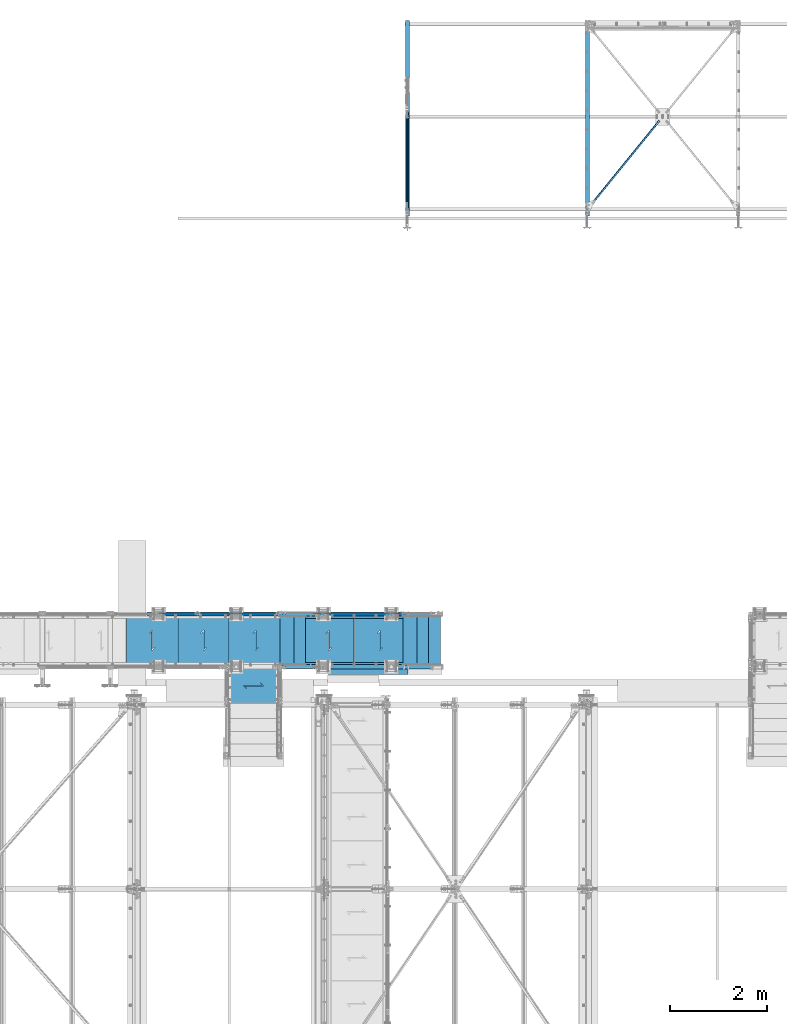
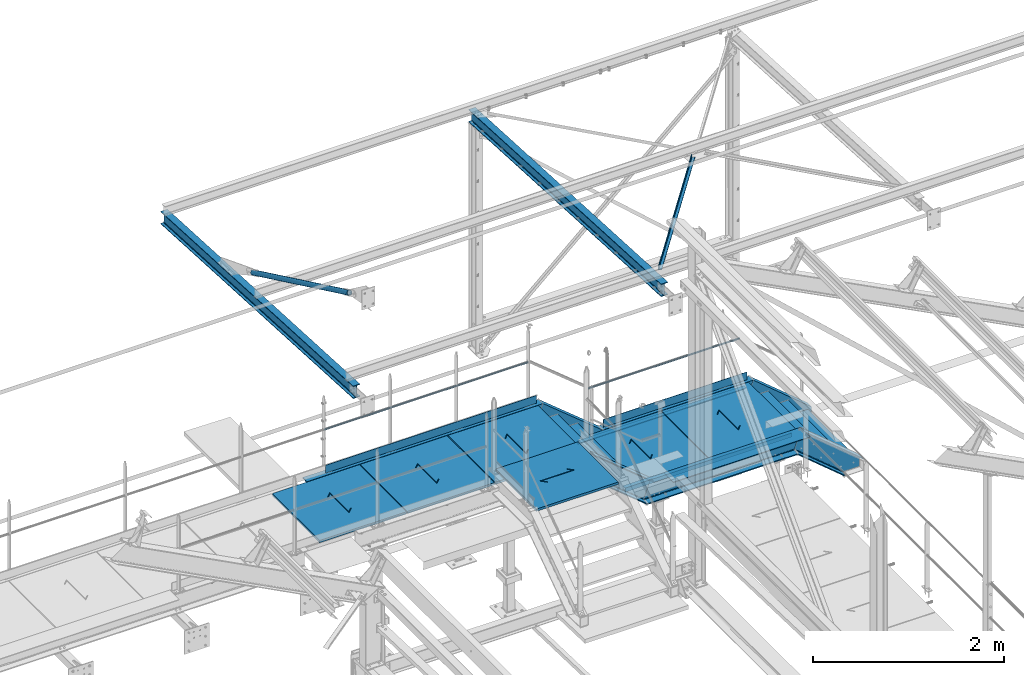
# One storey, part 53 of 496: 24 beams, 5 members, 21 elements without a shape of their own.
"""IFC2X3 building model written with IfcOpenShell, lengths in millimetres."""

from ifc_helpers import new_model, si_unit, frame, frame_2d, origin_with_axes, origin_2d_with_axis, place, context, subcontext, project, spatial, polyline, circle_curve, parameter, trimmed, segment, composite_curve, rectangle, hollow_circle, i_section, l_section, u_section, outline, extrude, boolean, clip, halfspace, material, type_object, element, aggregate, save


model = new_model("IFC2X3")

# Units and contexts
model_context = context("Model", 3, precision=1e-05, world=origin_with_axes())
body_context = subcontext(model_context, "Body", "Model", "MODEL_VIEW")
ifc_project = project(units=[si_unit("LENGTHUNIT", "METRE", prefix="MILLI"), si_unit("AREAUNIT", "SQUARE_METRE"), si_unit("VOLUMEUNIT", "CUBIC_METRE"), si_unit("MASSUNIT", "GRAM", prefix="KILO"), si_unit("TIMEUNIT", "SECOND"), si_unit("PLANEANGLEUNIT", "RADIAN"), si_unit("SOLIDANGLEUNIT", "STERADIAN"), si_unit("THERMODYNAMICTEMPERATUREUNIT", "DEGREE_CELSIUS"), si_unit("LUMINOUSINTENSITYUNIT", "LUMEN")], contexts=[model_context])

# Site, building, storey
site_placement = place(None, origin_with_axes())
site = spatial("IfcSite", under=ifc_project, at=site_placement, CompositionType="ELEMENT")
building_placement = place(site_placement, origin_with_axes())
building = spatial("IfcBuilding", under=site, at=building_placement, Name="Undefined", CompositionType="ELEMENT")
storey_placement = place(building_placement, origin_with_axes())
storey = spatial("IfcBuildingStorey", under=building, at=storey_placement, Name="Undefined", CompositionType="ELEMENT", Elevation=0.0)

# Assembly, beam
assembly_1_placement = place(storey_placement, origin_with_axes())
assembly_1 = element("IfcElementAssembly", 1, at=assembly_1_placement, inside=storey, Name="VIDE", AssemblyPlace="NOTDEFINED", PredefinedType="NOTDEFINED")
ifc_material_1 = material(Name="Undefined/S235-E24")
beam_type_1 = type_object("IfcBeamType", PredefinedType="NOTDEFINED")
beam_1_placement = place(assembly_1_placement, frame((25200.0099902533, 15929.9998774163, 8112.9999407383), z_axis=(0.0, -1.0, 0.0), x_axis=(-1.0, 0.0, 0.0)))
beam_1 = element("IfcBeam", 2, at=beam_1_placement, type_object=beam_type_1, material=ifc_material_1, Name="VIDE", context=body_context, shape_type="SweptSolid", body=[
    extrude(rectangle(XDim=6.0, YDim=200.0, at=origin_2d_with_axis()), frame((1650.0, 0.0, 0.0), z_axis=(-1.0, 0.0, 0.0), x_axis=(0.0, -1.0, 0.0)), (0.0, 0.0, 1.0), 1650.0),
])
aggregate(assembly_1, [beam_1])

# Assembly, beams
assembly_2_placement = place(storey_placement, origin_with_axes())
assembly_2 = element("IfcElementAssembly", 3, at=assembly_2_placement, inside=storey, Name="MAIN COURANTE", AssemblyPlace="NOTDEFINED", PredefinedType="NOTDEFINED")
beam_type_2 = type_object("IfcBeamType", PredefinedType="NOTDEFINED")
beam_2_placement = place(assembly_2_placement, frame((20059.9961849193, 17089.9946261742, 9243.80000001012), z_axis=(0.0, 1.0, 0.0), x_axis=(1.0, 0.0, 0.0)))
beam_2 = element("IfcBeam", 4, at=beam_2_placement, type_object=beam_type_2, material=ifc_material_1, Name="LISSE", context=body_context, shape_type="SweptSolid", body=[
    extrude(hollow_circle(Radius=10.64999962, WallThickness=2.0, at=origin_2d_with_axis()), frame((2460.01000000036, 1.81898940354586e-12, 0.0), z_axis=(-1.0, 0.0, 0.0), x_axis=(0.0, -1.0, 0.0)), (0.0, 0.0, 1.0), 2460.01),
])
beam_3_placement = place(assembly_2_placement, frame((23250.3145397259, 17089.9937511109, 8653.80000001012), z_axis=(0.0, 1.0, 0.0), x_axis=(1.0, 0.0, 0.0)))
beam_3 = element("IfcBeam", 5, at=beam_3_placement, type_object=beam_type_2, material=ifc_material_1, Name="LISSE", context=body_context, shape_type="Clipping", body=[
    clip(clip(extrude(hollow_circle(Radius=10.64999962, WallThickness=2.0, at=origin_2d_with_axis()), frame((1828.74844172951, -1.81898940354586e-12, 0.0), z_axis=(-1.0, 0.0, 0.0), x_axis=(0.0, -1.0, 0.0)), (0.0, 0.0, 1.0), 1836.49), halfspace(frame((1821.00987948852, 4.36557456851006e-10, -0.00100506085436791), z_axis=(0.940271589914334, 0.340425229969278, -5.78267025161579e-07), x_axis=(0.0, 0.0, 1.0)), False)), halfspace(frame((3.80609846943116, -10.6499996200018, 0.000112519468530081), z_axis=(0.941671113820088, 0.336534564935759, -5.79127732359695e-07), x_axis=(0.0, 0.0, 1.0)), True)),
])
beam_type_3 = type_object("IfcBeamType", PredefinedType="NOTDEFINED")
beam_4_placement = place(assembly_2_placement, frame((25144.9962475593, 17057.481480291, 8170.00000001012), z_axis=(0.0, 0.0, -1.0), x_axis=(-1.0, 0.0, 0.0)))
beam_4 = element("IfcBeam", 6, at=beam_4_placement, type_object=beam_type_3, material=ifc_material_1, context=body_context, shape_type="SweptSolid", body=[
    extrude(rectangle(XDim=5.0, YDim=100.0, at=origin_2d_with_axis()), frame((1734.99407492106, 0.0, 0.0), z_axis=(-1.0, 0.0, 0.0), x_axis=(0.0, -1.0, 0.0)), (0.0, 0.0, 1.0), 1734.99),
])
beam_5_placement = place(assembly_2_placement, frame((22604.9962475593, 17057.481480291, 8760.00000001012), z_axis=(0.0, 0.0, -1.0), x_axis=(-1.0, 0.0, 0.0)))
beam_5 = element("IfcBeam", 7, at=beam_5_placement, type_object=beam_type_3, material=ifc_material_1, context=body_context, shape_type="SweptSolid", body=[
    extrude(rectangle(XDim=5.0, YDim=100.0, at=origin_2d_with_axis()), frame((2550.00006264001, 0.0, 0.0), z_axis=(-1.0, 0.0, 0.0), x_axis=(0.0, -1.0, 0.0)), (0.0, 0.0, 1.0), 2550.0),
])
aggregate(assembly_2, [beam_2, beam_3, beam_4, beam_5])

# Assembly, beam
assembly_3_placement = place(storey_placement, origin_with_axes())
assembly_3 = element("IfcElementAssembly", 8, at=assembly_3_placement, inside=storey, Name="PALIER", AssemblyPlace="NOTDEFINED", PredefinedType="NOTDEFINED")
beam_type_4 = type_object("IfcBeamType", PredefinedType="NOTDEFINED")
beam_6_placement = place(assembly_3_placement, frame((20444.9999902344, 16530.001494552, 8685.0), z_axis=(0.0, 1.0, 0.0), x_axis=(-1.0, 0.0, 0.0)))
beam_6 = element("IfcBeam", 9, at=beam_6_placement, type_object=beam_type_4, material=ifc_material_1, Name="PALIER", context=body_context, shape_type="CSG", body=[
    boolean("DIFFERENCE", extrude(rectangle(XDim=30.0, YDim=990.0, at=origin_2d_with_axis()), frame((1050.0, 0.0, 0.0), z_axis=(-1.0, 0.0, 0.0), x_axis=(0.0, -1.0, 0.0)), (0.0, 0.0, 1.0), 1050.0), extrude(outline(polyline([(0.0, 0.0), (87.0678024292865, -7.27595761418343e-12), (-195.774902343946, 282.842712402629), (-132.842712402475, 282.842712402631), (-132.842712402482, 292.84271240264), (-219.917037964085, 292.84271240264), (62.9256706238448, 10.0000000000091), (-1.81898940354586e-10, 10.0000000000073), (0.0, 0.0)])), frame((468.433762432338, 17.4998126435639, -150.504333634472), z_axis=(0.0, -1.0, 0.0), x_axis=(0.707106781186548, 0.0, -0.707106781186548)), (0.0, 0.0, 1.0), 35.0)),
])
aggregate(assembly_3, [beam_6])

assembly_4_placement = place(storey_placement, origin_with_axes())
assembly_4 = element("IfcElementAssembly", 10, at=assembly_4_placement, inside=storey, Name="PALIER", AssemblyPlace="NOTDEFINED", PredefinedType="NOTDEFINED")
beam_7_placement = place(assembly_4_placement, frame((21504.9999902344, 16530.001494552, 8685.0), z_axis=(0.0, 1.0, 0.0), x_axis=(-1.0, 0.0, 0.0)))
beam_7 = element("IfcBeam", 11, at=beam_7_placement, type_object=beam_type_4, material=ifc_material_1, Name="PALIER", context=body_context, shape_type="CSG", body=[
    boolean("DIFFERENCE", extrude(rectangle(XDim=30.0, YDim=990.0, at=origin_2d_with_axis()), frame((1050.0, 0.0, 0.0), z_axis=(-1.0, 0.0, 0.0), x_axis=(0.0, -1.0, 0.0)), (0.0, 0.0, 1.0), 1050.0), extrude(outline(polyline([(0.0, 0.0), (87.0678024292865, -7.27595761418343e-12), (-195.774902343946, 282.842712402629), (-132.842712402475, 282.842712402631), (-132.842712402482, 292.84271240264), (-219.917037964085, 292.84271240264), (62.9256706238448, 10.0000000000091), (-1.81898940354586e-10, 10.0000000000073), (0.0, 0.0)])), frame((468.433762432338, 17.4998126435639, -150.504333634472), z_axis=(0.0, -1.0, 0.0), x_axis=(0.707106781186548, 0.0, -0.707106781186548)), (0.0, 0.0, 1.0), 35.0)),
])
aggregate(assembly_4, [beam_7])

assembly_5_placement = place(storey_placement, origin_with_axes())
assembly_5 = element("IfcElementAssembly", 12, at=assembly_5_placement, inside=storey, Name="PALIER", AssemblyPlace="NOTDEFINED", PredefinedType="NOTDEFINED")
beam_8_placement = place(assembly_5_placement, frame((22009.9938089558, 16019.9996347886, 8865.0), z_axis=(-1.0, 0.0, 0.0), x_axis=(0.0, -1.0, 0.0)))
beam_8 = element("IfcBeam", 13, at=beam_8_placement, type_object=beam_type_4, material=ifc_material_1, Name="PALIER", context=body_context, shape_type="CSG", body=[
    boolean("DIFFERENCE", extrude(rectangle(XDim=30.0, YDim=990.0, at=origin_2d_with_axis()), frame((844.999862133349, 0.0, 0.0), z_axis=(-1.0, 0.0, 0.0), x_axis=(0.0, -1.0, 0.0)), (0.0, 0.0, 1.0), 845.0), extrude(outline(polyline([(0.0, 0.0), (87.0678024292865, -7.27595761418343e-12), (-195.774902343946, 282.842712402629), (-132.842712402475, 282.842712402631), (-132.842712402482, 292.84271240264), (-219.917037964085, 292.84271240264), (62.9256706238448, 10.0000000000091), (-1.81898940354586e-10, 10.0000000000073), (0.0, 0.0)])), frame((365.93647293789, 17.4998126435639, -150.509457285396), z_axis=(0.0, -1.0, 0.0), x_axis=(0.707106781186548, 0.0, -0.707106781186548)), (0.0, 0.0, 1.0), 35.0)),
])
aggregate(assembly_5, [beam_8])

assembly_6_placement = place(storey_placement, origin_with_axes())
assembly_6 = element("IfcElementAssembly", 14, at=assembly_6_placement, inside=storey, Name="PALIER", AssemblyPlace="NOTDEFINED", PredefinedType="NOTDEFINED")
beam_9_placement = place(assembly_6_placement, frame((25144.9999902344, 16530.001494552, 8094.9999407569), z_axis=(0.0, 1.0, 0.0), x_axis=(-1.0, 0.0, 0.0)))
beam_9 = element("IfcBeam", 15, at=beam_9_placement, type_object=beam_type_4, material=ifc_material_1, Name="PALIER", context=body_context, shape_type="CSG", body=[
    boolean("DIFFERENCE", extrude(rectangle(XDim=30.0, YDim=990.0, at=origin_2d_with_axis()), frame((1050.0, 0.0, 0.0), z_axis=(-1.0, 0.0, 0.0), x_axis=(0.0, -1.0, 0.0)), (0.0, 0.0, 1.0), 1050.0), extrude(outline(polyline([(0.0, 0.0), (87.0678024292865, -7.27595761418343e-12), (-195.774902343946, 282.842712402629), (-132.842712402475, 282.842712402631), (-132.842712402482, 292.84271240264), (-219.917037964085, 292.84271240264), (62.9256706238448, 10.0000000000091), (-1.81898940354586e-10, 10.0000000000073), (0.0, 0.0)])), frame((468.433764126472, 17.5, -150.504124684554), z_axis=(0.0, -1.0, 0.0), x_axis=(0.707106781186548, 0.0, -0.707106781186548)), (0.0, 0.0, 1.0), 35.0)),
])
aggregate(assembly_6, [beam_9])

assembly_7_placement = place(storey_placement, origin_with_axes())
assembly_7 = element("IfcElementAssembly", 16, at=assembly_7_placement, inside=storey, Name="PALIER", AssemblyPlace="NOTDEFINED", PredefinedType="NOTDEFINED")
beam_10_placement = place(assembly_7_placement, frame((22604.9999902344, 16530.001494552, 8685.0), z_axis=(0.0, 1.0, 0.0), x_axis=(-1.0, 0.0, 0.0)))
beam_10 = element("IfcBeam", 17, at=beam_10_placement, type_object=beam_type_4, material=ifc_material_1, Name="PALIER", context=body_context, shape_type="CSG", body=[
    boolean("DIFFERENCE", extrude(rectangle(XDim=30.0, YDim=990.0, at=origin_2d_with_axis()), frame((1090.0, 0.0, 0.0), z_axis=(-1.0, 0.0, 0.0), x_axis=(0.0, -1.0, 0.0)), (0.0, 0.0, 1.0), 1090.0), extrude(outline(polyline([(0.0, 0.0), (87.0678024292865, -7.27595761418343e-12), (-195.774902343946, 282.842712402629), (-132.842712402475, 282.842712402631), (-132.842712402482, 292.84271240264), (-219.917037964085, 292.84271240264), (62.9256706238448, 10.0000000000091), (-1.81898940354586e-10, 10.0000000000073), (0.0, 0.0)])), frame((488.433762432338, 17.4998126435639, -150.504333634472), z_axis=(0.0, -1.0, 0.0), x_axis=(0.707106781186548, 0.0, -0.707106781186548)), (0.0, 0.0, 1.0), 35.0)),
])
aggregate(assembly_7, [beam_10])

assembly_8_placement = place(storey_placement, origin_with_axes())
assembly_8 = element("IfcElementAssembly", 18, at=assembly_8_placement, inside=storey, Name="PALIER", AssemblyPlace="NOTDEFINED", PredefinedType="NOTDEFINED")
beam_11_placement = place(assembly_8_placement, frame((24084.9999902344, 16530.001494552, 8094.9999407569), z_axis=(0.0, 1.0, 0.0), x_axis=(-1.0, 0.0, 0.0)))
beam_11 = element("IfcBeam", 19, at=beam_11_placement, type_object=beam_type_4, material=ifc_material_1, Name="PALIER", context=body_context, shape_type="CSG", body=[
    boolean("DIFFERENCE", extrude(rectangle(XDim=30.0, YDim=990.0, at=origin_2d_with_axis()), frame((1050.0, 0.0, 0.0), z_axis=(-1.0, 0.0, 0.0), x_axis=(0.0, -1.0, 0.0)), (0.0, 0.0, 1.0), 1050.0), extrude(outline(polyline([(0.0, 0.0), (87.0678024292865, -7.27595761418343e-12), (-195.774902343946, 282.842712402629), (-132.842712402475, 282.842712402631), (-132.842712402482, 292.84271240264), (-219.917037964085, 292.84271240264), (62.9256706238448, 10.0000000000091), (-1.81898940354586e-10, 10.0000000000073), (0.0, 0.0)])), frame((468.433764126472, 17.5, -150.504124684554), z_axis=(0.0, -1.0, 0.0), x_axis=(0.707106781186548, 0.0, -0.707106781186548)), (0.0, 0.0, 1.0), 35.0)),
])
aggregate(assembly_8, [beam_11])

assembly_9_placement = place(storey_placement, origin_with_axes())
assembly_9 = element("IfcElementAssembly", 20, at=assembly_9_placement, inside=storey, Name="SUPPORT", AssemblyPlace="NOTDEFINED", PredefinedType="NOTDEFINED")
beam_type_5 = type_object("IfcBeamType", PredefinedType="NOTDEFINED")
beam_12_placement = place(assembly_9_placement, frame((25094.9999902344, 17005.0001225837, 8054.9999407569), z_axis=(0.0, 0.0, -1.0), x_axis=(-1.0, 0.0, 0.0)))
beam_12 = element("IfcBeam", 21, at=beam_12_placement, type_object=beam_type_5, material=ifc_material_1, Name="SUPPORT", context=body_context, shape_type="SweptSolid", body=[
    extrude(l_section(Depth=50.0, Width=50.0, Thickness=5.0, FilletRadius=7.0, EdgeRadius=3.5, at=origin_2d_with_axis()), frame((2009.99999989913, 0.0, 0.0), z_axis=(-1.0, 0.0, 0.0), x_axis=(0.0, -1.0, 0.0)), (0.0, 0.0, 1.0), 2010.0),
])
aggregate(assembly_9, [beam_12])

assembly_10_placement = place(storey_placement, origin_with_axes())
assembly_10 = element("IfcElementAssembly", 22, at=assembly_10_placement, inside=storey, Name="SUPPORT", AssemblyPlace="NOTDEFINED", PredefinedType="NOTDEFINED")
beam_13_placement = place(assembly_10_placement, frame((23084.9999903352, 16054.9998774163, 8054.9999407569), z_axis=(0.0, 0.0, -1.0), x_axis=(1.0, 0.0, 0.0)))
beam_13 = element("IfcBeam", 23, at=beam_13_placement, type_object=beam_type_5, material=ifc_material_1, Name="SUPPORT", context=body_context, shape_type="SweptSolid", body=[
    extrude(l_section(Depth=50.0, Width=50.0, Thickness=5.0, FilletRadius=7.0, EdgeRadius=3.5, at=origin_2d_with_axis()), frame((2009.99999989913, 0.0, 0.0), z_axis=(-1.0, 0.0, 0.0), x_axis=(0.0, -1.0, 0.0)), (0.0, 0.0, 1.0), 2010.0),
])
aggregate(assembly_10, [beam_13])

# Assembly, member
assembly_11_placement = place(storey_placement, origin_with_axes())
assembly_11 = element("IfcElementAssembly", 24, at=assembly_11_placement, inside=storey, AssemblyPlace="NOTDEFINED", PredefinedType="NOTDEFINED")
ifc_material_2 = material(Name="Undefined/S275-E28")
member_type_1 = type_object("IfcMemberType", Name="UPN260", PredefinedType="NOTDEFINED")
member_1_placement = place(assembly_11_placement, frame((23303.6359782149, 15984.9998774375, 8009.44650543934), z_axis=(-0.63380948681209, 0.0, -0.77348919477068), x_axis=(-0.773488973625643, 0.0, 0.633809756693245)))
member_1 = element("IfcMember", 25, at=member_1_placement, type_object=member_type_1, material=ifc_material_2, ObjectType="UPN260", context=body_context, shape_type="Clipping", body=[
    clip(clip(extrude(u_section(Depth=260.0, FlangeWidth=90.0, WebThickness=10.0, FlangeThickness=14.0, FilletRadius=14.0, EdgeRadius=7.0, FlangeSlope=0.0798299857122373, at=origin_2d_with_axis()), frame((1123.44862759556, -1.81898940354586e-12, 0.0), z_axis=(-1.0, 0.0, 0.0), x_axis=(0.0, -1.0, 0.0)), (0.0, 0.0, 1.0), 1408.94), halfspace(frame((930.878776339017, 45.006178684931, -130.000000001099), z_axis=(0.941671627125962, 0.0, 0.336533128630664), x_axis=(0.0, -1.0, 0.0)), False)), halfspace(frame((-1.09252141555771e-07, 44.9999999787524, -129.999999907814), z_axis=(-0.941673964012416, 0.0, -0.336526589590099), x_axis=(0.0, 1.0, 0.0)), False)),
])

assembly_12_placement = place(storey_placement, origin_with_axes())
assembly_12 = element("IfcElementAssembly", 26, at=assembly_12_placement, inside=storey, AssemblyPlace="NOTDEFINED", PredefinedType="NOTDEFINED")
member_2_placement = place(assembly_12_placement, frame((22583.6110682815, 17074.9960163794, 8599.44642100542), z_axis=(-0.633810576130833, -1.31300000066403e-06, -0.773488302162985), x_axis=(0.773488302161326, 1.60200000082118e-06, -0.633810576132193)))
member_2 = element("IfcMember", 27, at=member_2_placement, type_object=member_type_1, material=ifc_material_2, ObjectType="UPN260", context=body_context, shape_type="Clipping", body=[
    clip(clip(extrude(u_section(Depth=260.0, FlangeWidth=90.0, WebThickness=10.0, FlangeThickness=14.0, FilletRadius=14.0, EdgeRadius=7.0, FlangeSlope=0.0798299857122373, at=origin_2d_with_axis()), frame((1216.36733735445, -2.10852457610342e-19, -3.63797880709171e-12), z_axis=(-1.0, 0.0, 0.0), x_axis=(0.0, -1.0, 0.0)), (0.0, 0.0, 1.0), 1408.94), halfspace(frame((930.877174444748, 1044.99780092066, -129.999997853567), z_axis=(0.941673490072606, 1.95042208498579e-06, -0.336527915767285), x_axis=(1.60200000027544e-06, -0.999999999997855, -1.31300000066404e-06)), False)), halfspace(frame((92.9171561234361, 1044.99611712716, 130.001182169719), z_axis=(-0.941671044923155, -1.95042715133223e-06, 0.336534757713865), x_axis=(1.60200000027544e-06, -0.999999999997855, -1.31300000066404e-06)), False)),
])

# Member
member_3_placement = place(assembly_11_placement, frame((25999.7706127592, 15984.9998774356, 7278.46901234049), z_axis=(-0.640184399664481, 0.0, -0.768221279597375), x_axis=(-0.768221279597376, 0.0, 0.640184399664479)))
member_3 = element("IfcMember", 28, at=member_3_placement, type_object=member_type_1, material=ifc_material_2, ObjectType="UPN260", context=body_context, shape_type="Clipping", body=[
    clip(clip(clip(extrude(u_section(Depth=260.0, FlangeWidth=90.0, WebThickness=10.0, FlangeThickness=14.0, FilletRadius=14.0, EdgeRadius=7.0, FlangeSlope=0.0798299857122373, at=origin_2d_with_axis()), frame((1237.09223205228, 1.81898940354586e-12, -3.70665122107218e-12), z_axis=(-1.0, 0.0, 0.0), x_axis=(0.0, -1.0, 0.0)), (0.0, 0.0, 1.0), 1237.09), halfspace(frame((245.689170201924, 45.0000000000891, -149.914659340717), z_axis=(-0.768221279597375, 0.0, -0.640184399664481), x_axis=(0.0, 1.0, 0.0)), False)), halfspace(frame((-72.2625156967988, 45.0000000000891, -189.778996649024), z_axis=(-0.640184399664479, 0.0, 0.768221279597377), x_axis=(0.0, 1.0, 0.0)), False)), halfspace(frame((1048.75984968731, 45.0000000018499, 130.000000000287), z_axis=(0.940271577725442, 0.0, 0.340425263636099), x_axis=(0.0, 1.0, 0.0)), False)),
])

member_4_placement = place(assembly_12_placement, frame((25121.7760182999, 17074.9998774393, 8010.13117439031), z_axis=(-0.640184399664481, 0.0, -0.768221279597375), x_axis=(0.768221279597365, 0.0, -0.640184399664493)))
member_4 = element("IfcMember", 29, at=member_4_placement, type_object=member_type_1, material=ifc_material_2, ObjectType="UPN260", context=body_context, shape_type="Clipping", body=[
    clip(clip(clip(extrude(u_section(Depth=260.0, FlangeWidth=90.0, WebThickness=10.0, FlangeThickness=14.0, FilletRadius=14.0, EdgeRadius=7.0, FlangeSlope=0.0798299857122373, at=origin_2d_with_axis()), frame((1142.89283280672, 0.0, 1.26886593766109e-13), z_axis=(-1.0, 0.0, 0.0), x_axis=(0.0, -1.0, 0.0)), (0.0, 0.0, 1.0), 1237.09), halfspace(frame((897.20366260222, 45.0, -149.914659340382), z_axis=(0.768221279597365, 0.0, -0.640184399664493), x_axis=(0.64018434015628, 0.0, 0.768221329187538)), False)), halfspace(frame((1215.15534850094, 45.0, -189.778996648689), z_axis=(0.64018434015628, 0.0, 0.768221329187538), x_axis=(-0.768221279597376, 0.0, 0.640184399664479)), False)), halfspace(frame((94.1329831168296, 1045.00000000176, 130.000000000626), z_axis=(-0.940271577725442, 0.0, 0.340425263636099), x_axis=(0.0, -1.0, 0.0)), False)),
])

# Beam
beam_type_6 = type_object("IfcBeamType", Name="UPN260", PredefinedType="NOTDEFINED")
beam_14_placement = place(assembly_12_placement, frame((23386.0289487381, 17074.9976786087, 7980.00020022042), z_axis=(0.0, 0.0, -1.0), x_axis=(0.999999999999259, 1.20900000090028e-06, -1.42999999767771e-07)))
beam_14 = element("IfcBeam", 30, at=beam_14_placement, type_object=beam_type_6, material=ifc_material_2, ObjectType="UPN260", context=body_context, shape_type="Clipping", body=[
    clip(clip(extrude(u_section(Depth=260.0, FlangeWidth=90.0, WebThickness=10.0, FlangeThickness=14.0, FilletRadius=14.0, EdgeRadius=7.0, FlangeSlope=0.0798299857122373, at=origin_2d_with_axis()), frame((1866.36594337937, -9.86806740857558e-20, 4.94022951773652e-20), z_axis=(-1.0, 0.0, 0.0), x_axis=(0.0, -1.0, 0.0)), (0.0, 0.0, 1.0), 2007.29), halfspace(frame((1818.9697595243, 1045.00000030639, -130.000000630604), z_axis=(0.940271626320907, 1.13678839794924e-06, 0.340425129411072), x_axis=(1.15500000027281e-06, -0.999999999999333, 0.0)), False)), halfspace(frame((-0.00120920079643838, 1044.99780119173, -130.000000000043), z_axis=(0.94167098396584, 1.13848022134454e-06, 0.336534928284585), x_axis=(1.15500000027281e-06, -0.999999999999333, 0.0)), True)),
])

beam_15_placement = place(assembly_11_placement, frame((25204.9999788015, 15984.9998774375, 7979.99994075731), z_axis=(0.0, 0.0, -1.0), x_axis=(-1.0, 0.0, 0.0)))
beam_15 = element("IfcBeam", 31, at=beam_15_placement, type_object=beam_type_6, material=ifc_material_2, ObjectType="UPN260", context=body_context, shape_type="Clipping", body=[
    clip(clip(extrude(u_section(Depth=260.0, FlangeWidth=90.0, WebThickness=10.0, FlangeThickness=14.0, FilletRadius=14.0, EdgeRadius=7.0, FlangeSlope=0.0798299857122373, at=origin_2d_with_axis()), frame((1959.89175727764, 0.0, 0.0), z_axis=(-1.0, 0.0, 0.0), x_axis=(0.0, -1.0, 0.0)), (0.0, 0.0, 1.0), 2007.29), halfspace(frame((1818.97096871192, 44.9999999787542, -130.000099393701), z_axis=(-0.941670965457109, 0.0, 0.336534980076479), x_axis=(0.0, 1.0, 0.0)), True)), halfspace(frame((-1.09252141555771e-07, 44.9999999787524, -129.999999907814), z_axis=(-0.940271577725442, 0.0, 0.340425263636099), x_axis=(0.0, 1.0, 0.0)), False)),
])

aggregate(assembly_11, [member_1, beam_15, member_3])

beam_16_placement = place(assembly_12_placement, frame((19815.0000560076, 17074.9998774373, 8570.00000000001), z_axis=(0.0, 0.0, -1.0), x_axis=(0.999999999998558, -1.69800000185205e-06, 0.0)))
beam_16 = element("IfcBeam", 32, at=beam_16_placement, type_object=beam_type_6, material=ifc_material_2, ObjectType="UPN260", context=body_context, shape_type="Clipping", body=[
    clip(extrude(u_section(Depth=260.0, FlangeWidth=90.0, WebThickness=10.0, FlangeThickness=14.0, FilletRadius=14.0, EdgeRadius=7.0, FlangeSlope=0.0798299857122373, at=origin_2d_with_axis()), frame((2851.47127539517, 3.63797847104186e-12, 0.0), z_axis=(-1.0, 0.0, 0.0), x_axis=(0.0, -1.0, 0.0)), (0.0, 0.0, 1.0), 2851.47), halfspace(frame((2851.00784014661, 1044.99631081776, -129.999999237325), z_axis=(0.941670806890972, -1.21852202211202e-06, 0.336535423763712), x_axis=(-1.69800000215235e-06, -0.999999999998558, 0.0)), False)),
])

aggregate(assembly_12, [beam_14, member_2, member_4, beam_16])

# Assembly, beam
assembly_13_placement = place(storey_placement, origin_with_axes())
assembly_13 = element("IfcElementAssembly", 33, at=assembly_13_placement, inside=storey, Name="MARCHE", AssemblyPlace="NOTDEFINED", PredefinedType="NOTDEFINED")
beam_type_7 = type_object("IfcBeamType", PredefinedType="NOTDEFINED")
beam_17_placement = place(assembly_13_placement, frame((25864.9999902344, 16530.001494552, 7495.0), z_axis=(0.0, 1.0, 0.0), x_axis=(-1.0, 0.0, 0.0)))
beam_17 = element("IfcBeam", 34, at=beam_17_placement, type_object=beam_type_7, material=ifc_material_1, Name="MARCHE", context=body_context, shape_type="SweptSolid", body=[
    extrude(rectangle(XDim=30.0, YDim=994.0, at=origin_2d_with_axis()), frame((290.0, 0.0, 0.0), z_axis=(-1.0, 0.0, 0.0), x_axis=(0.0, -1.0, 0.0)), (0.0, 0.0, 1.0), 290.0),
])
aggregate(assembly_13, [beam_17])

assembly_14_placement = place(storey_placement, origin_with_axes())
assembly_14 = element("IfcElementAssembly", 35, at=assembly_14_placement, inside=storey, Name="MARCHE", AssemblyPlace="NOTDEFINED", PredefinedType="NOTDEFINED")
beam_18_placement = place(assembly_14_placement, frame((25624.9999902344, 16530.001494552, 7695.0), z_axis=(0.0, 1.0, 0.0), x_axis=(-1.0, 0.0, 0.0)))
beam_18 = element("IfcBeam", 36, at=beam_18_placement, type_object=beam_type_7, material=ifc_material_1, Name="MARCHE", context=body_context, shape_type="SweptSolid", body=[
    extrude(rectangle(XDim=30.0, YDim=994.0, at=origin_2d_with_axis()), frame((290.0, 0.0, 0.0), z_axis=(-1.0, 0.0, 0.0), x_axis=(0.0, -1.0, 0.0)), (0.0, 0.0, 1.0), 290.0),
])
aggregate(assembly_14, [beam_18])

assembly_15_placement = place(storey_placement, origin_with_axes())
assembly_15 = element("IfcElementAssembly", 37, at=assembly_15_placement, inside=storey, Name="MARCHE", AssemblyPlace="NOTDEFINED", PredefinedType="NOTDEFINED")
beam_19_placement = place(assembly_15_placement, frame((23084.9999902344, 16530.001494552, 8291.6699407569), z_axis=(0.0, 1.0, 0.0), x_axis=(-1.0, 0.0, 0.0)))
beam_19 = element("IfcBeam", 38, at=beam_19_placement, type_object=beam_type_7, material=ifc_material_1, Name="MARCHE", context=body_context, shape_type="SweptSolid", body=[
    extrude(rectangle(XDim=30.0, YDim=994.0, at=origin_2d_with_axis()), frame((290.0, 0.0, 0.0), z_axis=(-1.0, 0.0, 0.0), x_axis=(0.0, -1.0, 0.0)), (0.0, 0.0, 1.0), 290.0),
])
aggregate(assembly_15, [beam_19])

assembly_16_placement = place(storey_placement, origin_with_axes())
assembly_16 = element("IfcElementAssembly", 39, at=assembly_16_placement, inside=storey, Name="MARCHE", AssemblyPlace="NOTDEFINED", PredefinedType="NOTDEFINED")
beam_20_placement = place(assembly_16_placement, frame((22844.9999902344, 16530.001494552, 8488.3299407569), z_axis=(0.0, 1.0, 0.0), x_axis=(-1.0, 0.0, 0.0)))
beam_20 = element("IfcBeam", 40, at=beam_20_placement, type_object=beam_type_7, material=ifc_material_1, Name="MARCHE", context=body_context, shape_type="SweptSolid", body=[
    extrude(rectangle(XDim=30.0, YDim=994.0, at=origin_2d_with_axis()), frame((290.0, 0.0, 0.0), z_axis=(-1.0, 0.0, 0.0), x_axis=(0.0, -1.0, 0.0)), (0.0, 0.0, 1.0), 290.0),
])
aggregate(assembly_16, [beam_20])

assembly_17_placement = place(storey_placement, origin_with_axes())
assembly_17 = element("IfcElementAssembly", 41, at=assembly_17_placement, inside=storey, Name="MARCHE", AssemblyPlace="NOTDEFINED", PredefinedType="NOTDEFINED")
beam_21_placement = place(assembly_17_placement, frame((25384.9999902344, 16530.001494552, 7894.9999407569), z_axis=(0.0, 1.0, 0.0), x_axis=(-1.0, 0.0, 0.0)))
beam_21 = element("IfcBeam", 42, at=beam_21_placement, type_object=beam_type_7, material=ifc_material_1, Name="MARCHE", context=body_context, shape_type="SweptSolid", body=[
    extrude(rectangle(XDim=30.0, YDim=994.0, at=origin_2d_with_axis()), frame((290.0, 0.0, 0.0), z_axis=(-1.0, 0.0, 0.0), x_axis=(0.0, -1.0, 0.0)), (0.0, 0.0, 1.0), 290.0),
])
aggregate(assembly_17, [beam_21])

assembly_18_placement = place(storey_placement, origin_with_axes())
assembly_18 = element("IfcElementAssembly", 43, at=assembly_18_placement, inside=storey, AssemblyPlace="NOTDEFINED", PredefinedType="NOTDEFINED")
beam_type_8 = type_object("IfcBeamType", PredefinedType="NOTDEFINED")
beam_22_placement = place(assembly_18_placement, frame((30451.4469799381, 27335.0746857039, 2960.81333331739), z_axis=(0.776487237630943, -0.629270284631704, 0.0329617759807083), x_axis=(-0.630132977867582, -0.775424175837016, 0.0406174559914615)))
beam_22 = element("IfcBeam", 44, at=beam_22_placement, type_object=beam_type_8, material=ifc_material_1, context=body_context, shape_type="Clipping", body=[
    clip(clip(extrude(l_section(Depth=40.0, Width=40.0, Thickness=4.0, FilletRadius=6.0, EdgeRadius=3.0, at=origin_2d_with_axis()), frame((2362.85080746814, -9.09494701772928e-13, -1.10316738496386e-12), z_axis=(-1.0, 0.0, 0.0), x_axis=(0.0, -1.0, 0.0)), (0.0, 0.0, 1.0), 2298.17), halfspace(frame((2320.08744063588, 182.999996914848, -19.9999998802577), z_axis=(1.0, 0.0, 0.0), x_axis=(0.0, -1.0, 0.0)), False)), halfspace(frame((107.441568612812, 182.999997959496, -19.9999998509284), z_axis=(1.0, 0.0, 0.0), x_axis=(0.0, -1.0, 0.0)), True)),
])
aggregate(assembly_18, [beam_22])

# Assembly, member
assembly_19_placement = place(storey_placement, origin_with_axes())
assembly_19 = element("IfcElementAssembly", 45, at=assembly_19_placement, inside=storey, AssemblyPlace="NOTDEFINED", PredefinedType="NOTDEFINED")
member_type_2 = type_object("IfcMemberType", PredefinedType="NOTDEFINED")
member_5_placement = place(assembly_19_placement, frame((25175.0000296668, 25040.0000675239, 4330.0), z_axis=(1.0, 0.0, 0.0), x_axis=(0.0, 0.902342243917931, -0.431020271960789)))
member_5 = element("IfcMember", 46, at=member_5_placement, type_object=member_type_2, material=ifc_material_1, context=body_context, shape_type="CSG", body=[
    boolean("DIFFERENCE", boolean("DIFFERENCE", boolean("DIFFERENCE", boolean("DIFFERENCE", extrude(hollow_circle(Radius=30.14999962, WallThickness=3.200000048, at=origin_2d_with_axis()), frame((3314.61716229229, 0.0, 0.0), z_axis=(-1.0, 0.0, 0.0), x_axis=(0.0, -1.0, 0.0)), (0.0, 0.0, 1.0), 3314.62), extrude(outline(composite_curve([segment(polyline([(0.0, 0.0), (80.00000000008, 8.00355337560177e-11), (80.0000000002909, 219.999999998219)]), True, "CONTINUOUS"), segment(trimmed(circle_curve(frame_2d((40.0000000002909, 219.999999998257), x_axis=(1.0, 0.0)), 40.0), [parameter(0.0)], [parameter(1.57079632679249)], True, "PARAMETER"), True, "CONTINUOUS"), segment(trimmed(circle_curve(frame_2d((40.0000000002909, 219.999999998257), x_axis=(0.0, 1.0)), 40.0), [parameter(0.0)], [parameter(1.57079632679703)], True, "PARAMETER"), True, "CONTINUOUS"), segment(polyline([(2.58576339826929e-10, 219.999999998304), (0.0, 0.0)]), True, "CONTINUOUS")], self_intersect=True)), frame((542.05606881866, 40.000004383508, 5.00000007788185), z_axis=(0.0, 0.0, -1.0), x_axis=(0.0, -1.0, 0.0)), (0.0, 0.0, 1.0), 10.0)), extrude(outline(composite_curve([segment(polyline([(0.0, 0.0), (80.00000000008, 8.00355337560177e-11), (80.0000000002909, 219.999999998219)]), True, "CONTINUOUS"), segment(trimmed(circle_curve(frame_2d((40.0000000002909, 219.999999998257), x_axis=(1.0, 0.0)), 40.0), [parameter(0.0)], [parameter(1.57079632679722)], True, "PARAMETER"), True, "CONTINUOUS"), segment(trimmed(circle_curve(frame_2d((40.0000000002909, 219.999999998257), x_axis=(0.0, 1.0)), 40.0), [parameter(0.0)], [parameter(1.57079632679236)], True, "PARAMETER"), True, "CONTINUOUS"), segment(polyline([(2.58576339826929e-10, 219.999999998304), (0.0, 0.0)]), True, "CONTINUOUS")], self_intersect=True)), frame((2534.92452783209, 40.0000043523614, -5.00000035937774), z_axis=(0.0, 0.0, 1.0), x_axis=(0.0, -1.0, 0.0)), (0.0, 0.0, 1.0), 10.0)), halfspace(frame((422.056068776183, 30.14999962, -30.14999962), z_axis=(-1.0, 0.0, 0.0), x_axis=(0.0, 0.0, 1.0)), False)), halfspace(frame((2654.92452778432, -30.14999962, -30.14999962), z_axis=(1.0, 0.0, 0.0), x_axis=(0.0, 0.0, 1.0)), False)),
])
aggregate(assembly_19, [member_5])

# Assembly, beam
assembly_20_placement = place(storey_placement, origin_with_axes())
assembly_20 = element("IfcElementAssembly", 47, at=assembly_20_placement, inside=storey, Name="TRAVERSE", AssemblyPlace="NOTDEFINED", PredefinedType="NOTDEFINED")
beam_type_9 = type_object("IfcBeamType", Name="IPE160", PredefinedType="NOTDEFINED")
beam_23_placement = place(assembly_20_placement, frame((25184.9999703351, 25285.8152378723, 2965.01428514327), z_axis=(-3.30331196424227e-10, 0.0523092382845414, 0.998630934625045), x_axis=(-6.99999093594944e-09, 0.998630934429248, -0.0523092420224877)))
beam_23 = element("IfcBeam", 48, at=beam_23_placement, type_object=beam_type_9, material=ifc_material_2, Name="TRAVERSE", ObjectType="IPE160", context=body_context, shape_type="Clipping", body=[
    clip(clip(extrude(i_section(OverallWidth=82.0, OverallDepth=160.0, WebThickness=5.0, FlangeThickness=7.400000095, FilletRadius=9.0, at=origin_2d_with_axis()), frame((4048.18022580932, -1.1706936320408e-20, 0.0), z_axis=(-1.0, 0.0, 0.0), x_axis=(0.0, -1.0, 0.0)), (0.0, 0.0, 1.0), 4052.45), halfspace(frame((4043.90593900933, -4.63187461718917e-07, -80.0000007383096), z_axis=(-0.998630934640944, 9.89046762331267e-10, -0.0523092379810284), x_axis=(0.0, -1.0, 0.0)), True)), halfspace(frame((4.69101107061942, -6.83940015733242e-09, -9.5556684303192), z_axis=(-0.998630934640944, 9.89046762331267e-10, -0.0523092379810284), x_axis=(0.0, -1.0, 0.0)), False)),
])
aggregate(assembly_20, [beam_23])

assembly_21_placement = place(storey_placement, origin_with_axes())
assembly_21 = element("IfcElementAssembly", 49, at=assembly_21_placement, inside=storey, Name="TRAVERSE", AssemblyPlace="NOTDEFINED", PredefinedType="NOTDEFINED")
beam_24_placement = place(assembly_21_placement, frame((28902.9999703351, 25285.8152378723, 2965.01428514327), z_axis=(-3.30331196424227e-10, 0.0523092382845414, 0.998630934625045), x_axis=(-6.99999093594944e-09, 0.998630934429248, -0.0523092420224877)))
beam_24 = element("IfcBeam", 50, at=beam_24_placement, type_object=beam_type_9, material=ifc_material_2, Name="TRAVERSE", ObjectType="IPE160", context=body_context, shape_type="Clipping", body=[
    clip(clip(extrude(i_section(OverallWidth=82.0, OverallDepth=160.0, WebThickness=5.0, FlangeThickness=7.400000095, FilletRadius=9.0, at=origin_2d_with_axis()), frame((4048.18022580932, -1.1706936320408e-20, 0.0), z_axis=(-1.0, 0.0, 0.0), x_axis=(0.0, -1.0, 0.0)), (0.0, 0.0, 1.0), 4052.45), halfspace(frame((4043.90593900933, -4.63187461718917e-07, -80.0000007383096), z_axis=(-0.998630934640944, 9.89046762331267e-10, -0.0523092379810284), x_axis=(0.0, -1.0, 0.0)), True)), halfspace(frame((4.69101107061942, -6.83940015733242e-09, -9.5556684303192), z_axis=(-0.998630934640944, 9.89046762331267e-10, -0.0523092379810284), x_axis=(0.0, -1.0, 0.0)), False)),
])
aggregate(assembly_21, [beam_24])

save(model, "model.ifc")
